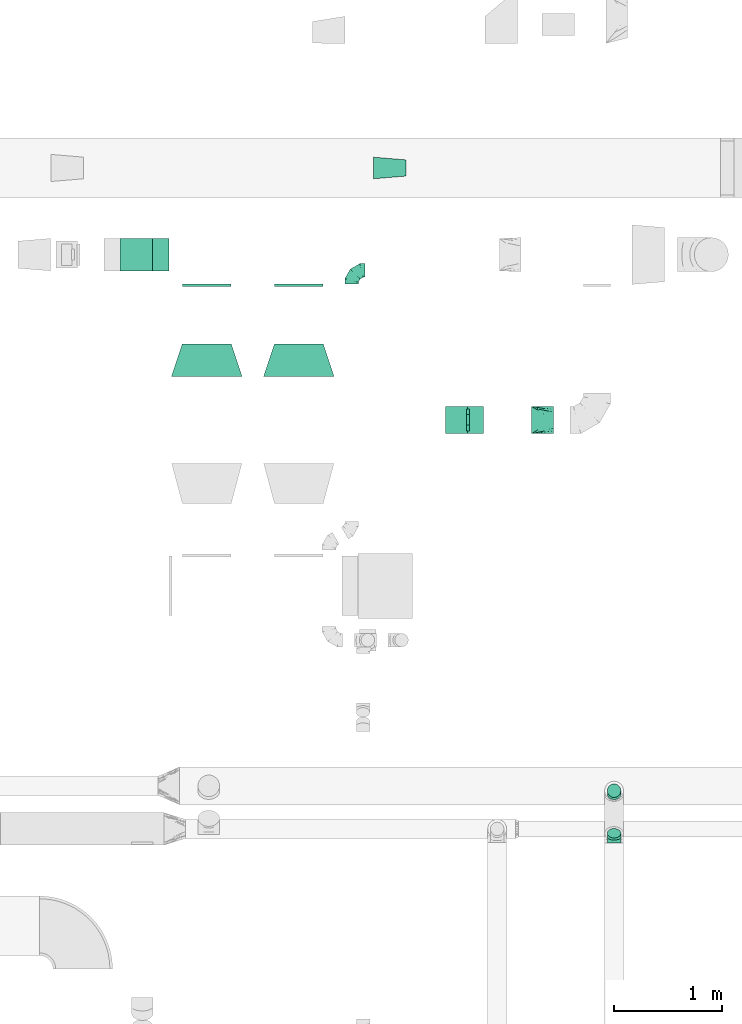
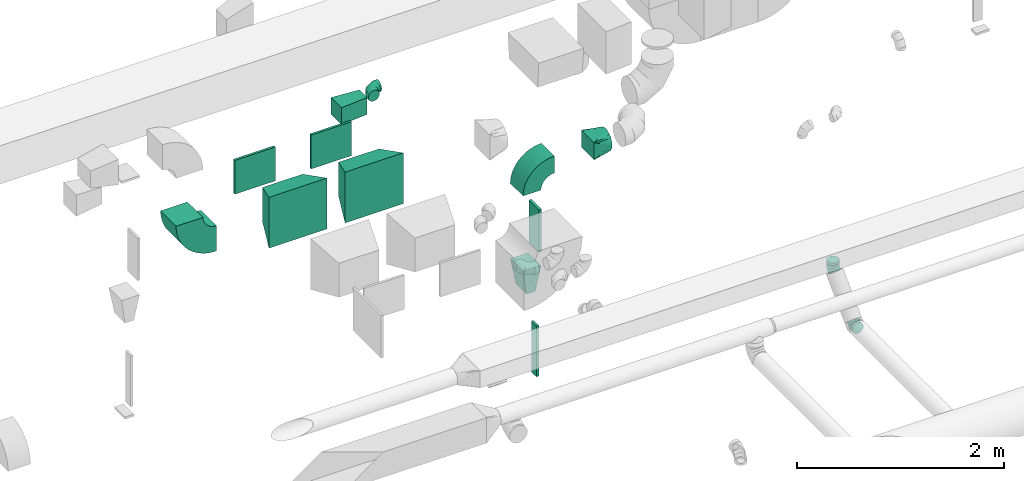
# One storey, part 58 of 97: 15 flow fittings.
"""IFC2X3 building model written with IfcOpenShell, lengths in millimetres."""

from ifc_helpers import new_model, entity, si_unit, converted_unit, derived_unit, direction, frame, frame_2d, origin, origin_2d_with_axis, place, context, subcontext, project, spatial, polyline, circle_curve, parameter, trimmed, segment, composite_curve, rectangle, outline, extrude, faceted_brep, source, transform, mapped, material, type_object, type_shapes, element, save


model = new_model("IFC2X3")

# Units and contexts
model_context = context("Model", 3, precision=0.01, world=origin(), true_north=direction((6.12303176911189e-17, 1.0)))
body_context = subcontext(model_context, "Body", "Model", "MODEL_VIEW")
ifc_project = project(units=[si_unit("LENGTHUNIT", "METRE", prefix="MILLI"), si_unit("AREAUNIT", "SQUARE_METRE"), si_unit("VOLUMEUNIT", "CUBIC_METRE"), converted_unit("PLANEANGLEUNIT", "DEGREE", entity("IfcRatioMeasure", 0.0174532925199433), si_unit("PLANEANGLEUNIT", "RADIAN"), dimensions=[0, 0, 0, 0, 0, 0, 0]), si_unit("MASSUNIT", "GRAM", prefix="KILO"), derived_unit("MASSDENSITYUNIT", [(si_unit("MASSUNIT", "GRAM", prefix="KILO"), 1), (si_unit("LENGTHUNIT", "METRE"), -3)]), derived_unit("MOMENTOFINERTIAUNIT", [(si_unit("LENGTHUNIT", "METRE"), 4)]), si_unit("TIMEUNIT", "SECOND"), si_unit("FREQUENCYUNIT", "HERTZ"), si_unit("THERMODYNAMICTEMPERATUREUNIT", "DEGREE_CELSIUS"), derived_unit("THERMALTRANSMITTANCEUNIT", [(si_unit("MASSUNIT", "GRAM", prefix="KILO"), 1), (si_unit("THERMODYNAMICTEMPERATUREUNIT", "KELVIN"), -1), (si_unit("TIMEUNIT", "SECOND"), -3)]), derived_unit("VOLUMETRICFLOWRATEUNIT", [(si_unit("LENGTHUNIT", "METRE"), 3), (si_unit("TIMEUNIT", "SECOND"), -1)]), derived_unit("MASSFLOWRATEUNIT", [(si_unit("MASSUNIT", "GRAM", prefix="KILO"), 1), (si_unit("TIMEUNIT", "SECOND"), -1)]), derived_unit("ROTATIONALFREQUENCYUNIT", [(si_unit("TIMEUNIT", "SECOND"), -1)]), si_unit("ELECTRICCURRENTUNIT", "AMPERE"), si_unit("ELECTRICVOLTAGEUNIT", "VOLT"), si_unit("POWERUNIT", "WATT"), si_unit("FORCEUNIT", "NEWTON", prefix="KILO"), si_unit("ILLUMINANCEUNIT", "LUX"), si_unit("LUMINOUSFLUXUNIT", "LUMEN"), si_unit("LUMINOUSINTENSITYUNIT", "CANDELA"), derived_unit("USERDEFINED", [(si_unit("MASSUNIT", "GRAM", prefix="KILO"), -1), (si_unit("LENGTHUNIT", "METRE"), -2), (si_unit("TIMEUNIT", "SECOND"), 3), (si_unit("LUMINOUSFLUXUNIT", "LUMEN"), 1)]), derived_unit("LINEARVELOCITYUNIT", [(si_unit("LENGTHUNIT", "METRE"), 1), (si_unit("TIMEUNIT", "SECOND"), -1)]), si_unit("PRESSUREUNIT", "PASCAL"), derived_unit("USERDEFINED", [(si_unit("LENGTHUNIT", "METRE"), -2), (si_unit("MASSUNIT", "GRAM", prefix="KILO"), 1), (si_unit("TIMEUNIT", "SECOND"), -2)]), derived_unit("LINEARFORCEUNIT", [(si_unit("MASSUNIT", "GRAM", prefix="KILO"), 1), (si_unit("LENGTHUNIT", "METRE"), 1), (si_unit("TIMEUNIT", "SECOND"), -2), (si_unit("LENGTHUNIT", "METRE"), -1)]), derived_unit("PLANARFORCEUNIT", [(si_unit("MASSUNIT", "GRAM", prefix="KILO"), 1), (si_unit("LENGTHUNIT", "METRE"), 1), (si_unit("TIMEUNIT", "SECOND"), -2), (si_unit("LENGTHUNIT", "METRE"), -2)])], contexts=[model_context])

# Site, building, storey
site_placement = place(None, origin())
site = spatial("IfcSite", under=ifc_project, at=site_placement, CompositionType="ELEMENT")
building_placement = place(site_placement, origin())
building = spatial("IfcBuilding", under=site, at=building_placement, CompositionType="ELEMENT")
storey_placement = place(building_placement, frame((0.0, 0.0, -4900.0)))
storey = spatial("IfcBuildingStorey", under=building, at=storey_placement, CompositionType="ELEMENT", Elevation=-4900.0)

# Flow fittings
ifc_material = material()
duct_fitting_type_1 = type_object("IfcDuctFittingType", PredefinedType="NOTDEFINED", material=ifc_material)
shared_shape_1 = source(origin(), body_context, "Body", "SweptSolid", [
    extrude(outline(polyline([(-143.25, -87.2), (157.79, -87.2), (141.18, 112.11), (-155.71, 62.28), (-143.25, -87.2)])), frame((150.0, 0.0, -100.0), z_axis=(0.0, 0.0, 1.0), x_axis=(0.996545758244879, -0.0830454798537418, 0.0)), (0.0, 0.0, 1.0), 200.0),
])
type_shapes(duct_fitting_type_1, [shared_shape_1])
flow_fitting_1_placement = place(storey_placement, frame((45445.8, 15348.96, 3300.0), z_axis=(0.0, 0.0, 1.0), x_axis=(-1.0, 0.0, 0.0)))
element("IfcFlowFitting", 1, at=flow_fitting_1_placement, inside=storey, type_object=duct_fitting_type_1, material=ifc_material, context=body_context, shape_type="MappedRepresentation", body=[
    mapped(shared_shape_1, transform((0.0, 0.0, 0.0), scale=1.0)),
])
duct_fitting_type_2 = type_object("IfcDuctFittingType", PredefinedType="NOTDEFINED", material=ifc_material)
shared_shape_2 = source(origin(), body_context, "Body", "SweptSolid", [
    extrude(rectangle(XDim=26.0960000000008, YDim=500.0, at=origin_2d_with_axis()), frame((6.95, 0.0, -100.0)), (0.0, 0.0, 1.0), 200.0),
])
type_shapes(duct_fitting_type_2, [shared_shape_2])
flow_fitting_2_placement = place(storey_placement, frame((46014.19, 13020.83, 3050.0), z_axis=(0.0, -1.0, 0.0), x_axis=(1.0, 0.0, 0.0)))
element("IfcFlowFitting", 2, at=flow_fitting_2_placement, inside=storey, type_object=duct_fitting_type_2, material=ifc_material, context=body_context, shape_type="MappedRepresentation", body=[
    mapped(shared_shape_2, transform((0.0, 0.0, 0.0), scale=1.0)),
])
duct_fitting_type_3 = type_object("IfcDuctFittingType", PredefinedType="NOTDEFINED", material=ifc_material)
shared_shape_3 = source(origin(), body_context, "Body", "SweptSolid", [
    extrude(rectangle(XDim=26.0960000000009, YDim=600.0, at=origin_2d_with_axis()), frame((6.95, 0.0, -50.0)), (0.0, 0.0, 1.0), 100.0),
])
type_shapes(duct_fitting_type_3, [shared_shape_3])
flow_fitting_3_placement = place(storey_placement, frame((46014.19, 13024.36, 1600.0), z_axis=(0.0, -1.0, 0.0), x_axis=(1.0, 0.0, 0.0)))
element("IfcFlowFitting", 3, at=flow_fitting_3_placement, inside=storey, type_object=duct_fitting_type_3, material=ifc_material, context=body_context, shape_type="MappedRepresentation", body=[
    mapped(shared_shape_3, transform((0.0, 0.0, 0.0), scale=1.0)),
])
duct_fitting_type_4 = type_object("IfcDuctFittingType", PredefinedType="NOTDEFINED", material=ifc_material)
shared_shape_4 = source(origin(), body_context, "Body", "SweptSolid", [
    extrude(rectangle(XDim=26.0960000000029, YDim=450.0, at=origin_2d_with_axis()), frame((6.95, 0.0, -200.0)), (0.0, 0.0, 1.0), 400.0),
])
type_shapes(duct_fitting_type_4, [shared_shape_4])
for number, where, z_axis, x_axis in (
    (4, (43607.27, 14273.39, 3800.0), (0.0, 0.0, -1.0), (0.0, -1.0, 0.0)),
    (5, (44457.27, 14273.39, 3800.0), (0.0, 0.0, -1.0), (0.0, -1.0, 0.0)),
):
    element("IfcFlowFitting", number, at=place(storey_placement, frame(where, z_axis=z_axis, x_axis=x_axis)), inside=storey, type_object=duct_fitting_type_4, material=ifc_material, context=body_context, shape_type="MappedRepresentation", body=[
        mapped(shared_shape_4, transform((0.0, 0.0, 0.0), scale=1.0)),
    ])
duct_fitting_type_5 = type_object("IfcDuctFittingType", PredefinedType="NOTDEFINED", material=ifc_material)
shared_shape_5 = source(origin(), body_context, "Body", "Brep", [
    faceted_brep([(-125.0, 0.0, -62.5), (-125.0, -16.18, -60.37), (-125.0, -31.25, -54.13), (-125.0, -44.19, -44.19), (-125.0, -54.13, -31.25), (-125.0, -60.37, -16.18), (-125.0, -62.5, 0.0), (-125.0, -60.37, 16.18), (-125.0, -54.13, 31.25), (-125.0, -44.19, 44.19), (-125.0, -31.25, 54.13), (-125.0, -16.18, 60.37), (-125.0, 0.0, 62.5), (-125.0, 16.18, 60.37), (-125.0, 31.25, 54.13), (-125.0, 44.19, 44.19), (-125.0, 54.13, 31.25), (-125.0, 60.37, 16.18), (-125.0, 62.5, 0.0), (-125.0, 60.37, -16.18), (-125.0, 54.13, -31.25), (-125.0, 44.19, -44.19), (-125.0, 31.25, -54.13), (-125.0, 16.18, -60.37), (-95.84, 16.18, 60.37), (-99.88, 31.25, 54.13), (-91.51, 0.0, 62.5), (-103.35, 44.19, 44.19), (-107.68, 60.37, 16.18), (-108.25, 62.5, 0.0), (-106.01, 54.13, 31.25), (-106.01, 54.13, -31.25), (-103.35, 44.19, -44.19), (-107.68, 60.37, -16.18), (-95.84, 16.18, -60.37), (-91.51, 0.0, -62.5), (-99.88, 31.25, -54.13), (-87.17, -16.18, -60.37), (-83.13, -31.25, -54.13), (-79.66, -44.19, -44.19), (-77.0, -54.13, -31.25), (-75.33, -60.37, -16.18), (-74.76, -62.5, 0.0), (-75.33, -60.37, 16.18), (-77.0, -54.13, 31.25), (-79.66, -44.19, 44.19), (-83.13, -31.25, 54.13), (-87.17, -16.18, 60.37), (-45.34, 45.34, 60.37), (-56.37, 56.37, 54.13), (-33.49, 33.49, 62.5), (-65.85, 65.85, 44.19), (-73.12, 73.12, 31.25), (-77.69, 77.69, 16.18), (-79.25, 79.25, 0.0), (-77.69, 77.69, -16.18), (-73.12, 73.12, -31.25), (-65.85, 65.85, -44.19), (-45.34, 45.34, -60.37), (-33.49, 33.49, -62.5), (-56.37, 56.37, -54.13), (-21.65, 21.65, -60.37), (-10.62, 10.62, -54.13), (-1.14, 1.14, -44.19), (6.13, -6.13, -31.25), (10.7, -10.7, -16.18), (12.26, -12.26, 0.0), (10.7, -10.7, 16.18), (6.13, -6.13, 31.25), (-1.14, 1.14, 44.19), (-10.62, 10.62, 54.13), (-21.65, 21.65, 60.37), (-16.18, 95.84, 60.37), (-31.25, 99.88, 54.13), (0.0, 91.51, 62.5), (-44.19, 103.35, 44.19), (-54.13, 106.01, 31.25), (-60.37, 107.68, 16.18), (-62.5, 108.25, 0.0), (-60.37, 107.68, -16.18), (-54.13, 106.01, -31.25), (-44.19, 103.35, -44.19), (-16.18, 95.84, -60.37), (0.0, 91.51, -62.5), (-31.25, 99.88, -54.13), (16.18, 87.17, -60.37), (31.25, 83.13, -54.13), (44.19, 79.66, -44.19), (54.13, 77.0, -31.25), (60.37, 75.33, -16.18), (62.5, 74.76, 0.0), (60.37, 75.33, 16.18), (54.13, 77.0, 31.25), (44.19, 79.66, 44.19), (31.25, 83.13, 54.13), (16.18, 87.17, 60.37), (-16.18, 125.0, -60.37), (-31.25, 125.0, -54.13), (-44.19, 125.0, -44.19), (-54.13, 125.0, -31.25), (-60.37, 125.0, -16.18), (-62.5, 125.0, 0.0), (-60.37, 125.0, 16.18), (-54.13, 125.0, 31.25), (-44.19, 125.0, 44.19), (-31.25, 125.0, 54.13), (-16.18, 125.0, 60.37), (0.0, 125.0, 62.5), (16.18, 125.0, 60.37), (31.25, 125.0, 54.13), (44.19, 125.0, 44.19), (54.13, 125.0, 31.25), (60.37, 125.0, 16.18), (62.5, 125.0, 0.0), (60.37, 125.0, -16.18), (54.13, 125.0, -31.25), (44.19, 125.0, -44.19), (31.25, 125.0, -54.13), (16.18, 125.0, -60.37), (0.0, 125.0, -62.5)], [[[0, 1, 2, 3, 4, 5, 6, 7, 8, 9, 10, 11, 12, 13, 14, 15, 16, 17, 18, 19, 20, 21, 22, 23]], [[24, 25, 14, 13]], [[26, 24, 13, 12]], [[14, 25, 27, 15]], [[28, 29, 18, 17]], [[30, 28, 17, 16]], [[15, 27, 30, 16]], [[20, 31, 32, 21]], [[33, 31, 20, 19]], [[18, 29, 33, 19]], [[34, 35, 0, 23]], [[36, 34, 23, 22]], [[21, 32, 36, 22]], [[1, 0, 35, 37]], [[2, 1, 37, 38]], [[38, 39, 3, 2]], [[5, 4, 40, 41]], [[6, 5, 41, 42]], [[39, 40, 4, 3]], [[6, 42, 43, 7]], [[7, 43, 44, 8]], [[45, 9, 8, 44]], [[9, 45, 46, 10]], [[10, 46, 47, 11]], [[26, 12, 11, 47]], [[48, 49, 25, 24]], [[50, 48, 24, 26]], [[27, 25, 49, 51]], [[52, 53, 28, 30]], [[51, 52, 30, 27]], [[29, 28, 53, 54]], [[55, 56, 31, 33]], [[54, 55, 33, 29]], [[57, 32, 31, 56]], [[58, 59, 35, 34]], [[60, 58, 34, 36]], [[57, 60, 36, 32]], [[37, 35, 59, 61]], [[38, 37, 61, 62]], [[39, 38, 62, 63]], [[41, 40, 64, 65]], [[42, 41, 65, 66]], [[63, 64, 40, 39]], [[43, 42, 66, 67]], [[44, 43, 67, 68]], [[68, 69, 45, 44]], [[46, 45, 69, 70]], [[47, 46, 70, 71]], [[26, 47, 71, 50]], [[72, 73, 49, 48]], [[74, 72, 48, 50]], [[51, 49, 73, 75]], [[76, 77, 53, 52]], [[75, 76, 52, 51]], [[54, 53, 77, 78]], [[79, 80, 56, 55]], [[78, 79, 55, 54]], [[81, 57, 56, 80]], [[82, 83, 59, 58]], [[84, 82, 58, 60]], [[81, 84, 60, 57]], [[61, 59, 83, 85]], [[62, 61, 85, 86]], [[63, 62, 86, 87]], [[65, 64, 88, 89]], [[66, 65, 89, 90]], [[87, 88, 64, 63]], [[67, 66, 90, 91]], [[68, 67, 91, 92]], [[92, 93, 69, 68]], [[70, 69, 93, 94]], [[71, 70, 94, 95]], [[50, 71, 95, 74]], [[96, 97, 98, 99, 100, 101, 102, 103, 104, 105, 106, 107, 108, 109, 110, 111, 112, 113, 114, 115, 116, 117, 118, 119]], [[72, 74, 107, 106]], [[73, 72, 106, 105]], [[75, 73, 105, 104]], [[77, 76, 103, 102]], [[78, 77, 102, 101]], [[75, 104, 103, 76]], [[78, 101, 100, 79]], [[79, 100, 99, 80]], [[80, 99, 98, 81]], [[96, 119, 83, 82]], [[97, 96, 82, 84]], [[84, 81, 98, 97]], [[83, 119, 118, 85]], [[85, 118, 117, 86]], [[116, 87, 86, 117]], [[88, 115, 114, 89]], [[89, 114, 113, 90]], [[115, 88, 87, 116]], [[91, 90, 113, 112]], [[92, 91, 112, 111]], [[111, 110, 93, 92]], [[95, 94, 109, 108]], [[74, 95, 108, 107]], [[110, 109, 94, 93]]]),
])
type_shapes(duct_fitting_type_5, [shared_shape_5])
flow_fitting_4_placement = place(storey_placement, frame((44945.15, 14402.31, 4200.0), z_axis=(0.0, 0.0, 1.0), x_axis=(-1.0, 0.0, 0.0)))
element("IfcFlowFitting", 6, at=flow_fitting_4_placement, inside=storey, type_object=duct_fitting_type_5, material=ifc_material, context=body_context, shape_type="MappedRepresentation", body=[
    mapped(shared_shape_5, transform((0.0, 0.0, 0.0), scale=1.0)),
])
duct_fitting_type_6 = type_object("IfcDuctFittingType", PredefinedType="NOTDEFINED", material=ifc_material)
shared_shape_6 = source(origin(), body_context, "Body", "Brep", [
    faceted_brep([(20.0, 0.0, -62.5), (20.0, 16.18, -60.37), (20.0, 31.25, -54.13), (20.0, 44.19, -44.19), (20.0, 54.13, -31.25), (20.0, 60.37, -16.18), (20.0, 62.5, 0.0), (20.0, 60.37, 16.18), (20.0, 54.13, 31.25), (20.0, 44.19, 44.19), (20.0, 31.25, 54.13), (20.0, 16.18, 60.37), (20.0, 0.0, 62.5), (20.0, -16.18, 60.37), (20.0, -31.25, 54.13), (20.0, -44.19, 44.19), (20.0, -54.13, 31.25), (20.0, -60.37, 16.18), (20.0, -62.5, 0.0), (20.0, -60.37, -16.18), (20.0, -54.13, -31.25), (20.0, -44.19, -44.19), (20.0, -31.25, -54.13), (20.0, -16.18, -60.37), (0.0, 0.0, 62.5), (-6.1, 0.0, 62.5), (-6.1, -16.18, 60.37), (0.0, -16.18, 60.37), (-6.1, -31.25, 54.13), (0.0, -31.25, 54.13), (0.0, -44.19, 44.19), (-6.1, -44.19, 44.19), (0.0, -54.13, 31.25), (-6.1, -54.13, 31.25), (-6.1, -60.37, 16.18), (0.0, -60.37, 16.18), (-6.1, -62.5, 0.0), (0.0, -62.5, 0.0), (-6.1, -60.37, -16.18), (0.0, -60.37, -16.18), (-6.1, -54.13, -31.25), (0.0, -54.13, -31.25), (0.0, -44.19, -44.19), (-6.1, -44.19, -44.19), (0.0, -31.25, -54.13), (-6.1, -31.25, -54.13), (-6.1, -16.18, -60.37), (0.0, -16.18, -60.37), (-6.1, 0.0, -62.5), (0.0, 0.0, -62.5), (-6.1, 16.18, -60.37), (0.0, 16.18, -60.37), (-6.1, 31.25, -54.13), (0.0, 31.25, -54.13), (0.0, 44.19, -44.19), (-6.1, 44.19, -44.19), (0.0, 54.13, -31.25), (-6.1, 54.13, -31.25), (-6.1, 60.37, -16.18), (0.0, 60.37, -16.18), (-6.1, 62.5, 0.0), (0.0, 62.5, 0.0), (-6.1, 60.37, 16.18), (0.0, 60.37, 16.18), (-6.1, 54.13, 31.25), (0.0, 54.13, 31.25), (0.0, 44.19, 44.19), (-6.1, 44.19, 44.19), (0.0, 31.25, 54.13), (-6.1, 31.25, 54.13), (-6.1, 16.18, 60.37), (0.0, 16.18, 60.37)], [[[0, 1, 2, 3, 4, 5, 6, 7, 8, 9, 10, 11, 12, 13, 14, 15, 16, 17, 18, 19, 20, 21, 22, 23]], [[13, 12, 24, 25, 26, 27]], [[14, 13, 27, 26, 28, 29]], [[30, 15, 14, 29, 28, 31]], [[17, 16, 32, 33, 34, 35]], [[18, 17, 35, 34, 36, 37]], [[32, 16, 15, 30, 31, 33]], [[19, 18, 37, 36, 38, 39]], [[20, 19, 39, 38, 40, 41]], [[42, 21, 20, 41, 40, 43]], [[23, 22, 44, 45, 46, 47]], [[0, 23, 47, 46, 48, 49]], [[44, 22, 21, 42, 43, 45]], [[1, 0, 49, 48, 50, 51]], [[2, 1, 51, 50, 52, 53]], [[54, 3, 2, 53, 52, 55]], [[5, 4, 56, 57, 58, 59]], [[6, 5, 59, 58, 60, 61]], [[56, 4, 3, 54, 55, 57]], [[7, 6, 61, 60, 62, 63]], [[8, 7, 63, 62, 64, 65]], [[66, 9, 8, 65, 64, 67]], [[11, 10, 68, 69, 70, 71]], [[12, 11, 71, 70, 25, 24]], [[68, 10, 9, 66, 67, 69]], [[46, 45, 43, 40, 38, 36, 34, 33, 31, 28, 26, 25, 70, 69, 67, 64, 62, 60, 58, 57, 55, 52, 50, 48]]]),
])
type_shapes(duct_fitting_type_6, [shared_shape_6])
flow_fitting_5_placement = place(storey_placement, frame((47368.94, 9598.15, 4250.0), z_axis=(1.0, 0.0, 0.0), x_axis=(0.0, 0.0, -1.0)))
element("IfcFlowFitting", 7, at=flow_fitting_5_placement, inside=storey, type_object=duct_fitting_type_6, material=ifc_material, context=body_context, shape_type="MappedRepresentation", body=[
    mapped(shared_shape_6, transform((0.0, 0.0, 0.0), scale=1.0)),
])
duct_fitting_type_7 = type_object("IfcDuctFittingType", PredefinedType="NOTDEFINED", material=ifc_material)
shared_shape_7 = source(origin(), body_context, "Body", "Brep", [
    faceted_brep([(-51.78, 0.0, -62.5), (-51.78, -16.18, -60.37), (-51.78, -31.25, -54.13), (-51.78, -44.19, -44.19), (-51.78, -54.13, -31.25), (-51.78, -60.37, -16.18), (-51.78, -62.5, 0.0), (-51.78, -60.37, 16.18), (-51.78, -54.13, 31.25), (-51.78, -44.19, 44.19), (-51.78, -31.25, 54.13), (-51.78, -16.18, 60.37), (-51.78, 0.0, 62.5), (-51.78, 16.18, 60.37), (-51.78, 31.25, 54.13), (-51.78, 44.19, 44.19), (-51.78, 54.13, 31.25), (-51.78, 60.37, 16.18), (-51.78, 62.5, 0.0), (-51.78, 60.37, -16.18), (-51.78, 54.13, -31.25), (-51.78, 44.19, -44.19), (-51.78, 31.25, -54.13), (-51.78, 16.18, -60.37), (-6.7, 16.18, 60.37), (-12.94, 31.25, 54.13), (0.0, 0.0, 62.5), (-18.31, 44.19, 44.19), (-22.42, 54.13, 31.25), (-25.01, 60.37, 16.18), (-25.89, 62.5, 0.0), (-25.01, 60.37, -16.18), (-22.42, 54.13, -31.25), (-18.31, 44.19, -44.19), (-6.7, 16.18, -60.37), (0.0, 0.0, -62.5), (-12.94, 31.25, -54.13), (6.7, -16.18, -60.37), (12.94, -31.25, -54.13), (18.31, -44.19, -44.19), (22.42, -54.13, -31.25), (25.01, -60.37, -16.18), (25.89, -62.5, 0.0), (25.01, -60.37, 16.18), (22.42, -54.13, 31.25), (18.31, -44.19, 44.19), (12.94, -31.25, 54.13), (6.7, -16.18, 60.37), (25.17, 48.05, 60.37), (14.51, 58.71, 54.13), (36.61, 36.61, 62.5), (5.36, 67.86, 44.19), (-1.66, 74.88, 31.25), (-6.08, 79.3, 16.18), (-7.58, 80.81, 0.0), (-6.08, 79.3, -16.18), (-1.66, 74.88, -31.25), (5.36, 67.86, -44.19), (14.51, 58.71, -54.13), (25.17, 48.05, -60.37), (36.61, 36.61, -62.5), (48.05, 25.17, -60.37), (58.71, 14.51, -54.13), (67.86, 5.36, -44.19), (74.88, -1.66, -31.25), (79.3, -6.08, -16.18), (80.81, -7.58, 0.0), (79.3, -6.08, 16.18), (74.88, -1.66, 31.25), (67.86, 5.36, 44.19), (58.71, 14.51, 54.13), (48.05, 25.17, 60.37)], [[[0, 1, 2, 3, 4, 5, 6, 7, 8, 9, 10, 11, 12, 13, 14, 15, 16, 17, 18, 19, 20, 21, 22, 23]], [[24, 25, 14, 13]], [[26, 24, 13, 12]], [[27, 15, 14, 25]], [[28, 29, 17, 16]], [[28, 16, 15, 27]], [[30, 18, 17, 29]], [[31, 32, 20, 19]], [[30, 31, 19, 18]], [[21, 20, 32, 33]], [[34, 35, 0, 23]], [[36, 34, 23, 22]], [[33, 36, 22, 21]], [[1, 0, 35, 37]], [[2, 1, 37, 38]], [[38, 39, 3, 2]], [[5, 4, 40, 41]], [[6, 5, 41, 42]], [[39, 40, 4, 3]], [[6, 42, 43, 7]], [[7, 43, 44, 8]], [[8, 44, 45, 9]], [[9, 45, 46, 10]], [[10, 46, 47, 11]], [[26, 12, 11, 47]], [[48, 49, 25, 24]], [[50, 48, 24, 26]], [[27, 25, 49, 51]], [[29, 28, 52, 53]], [[30, 29, 53, 54]], [[51, 52, 28, 27]], [[30, 54, 55, 31]], [[31, 55, 56, 32]], [[57, 33, 32, 56]], [[36, 58, 59, 34]], [[34, 59, 60, 35]], [[58, 36, 33, 57]], [[35, 60, 61, 37]], [[37, 61, 62, 38]], [[63, 39, 38, 62]], [[40, 64, 65, 41]], [[41, 65, 66, 42]], [[64, 40, 39, 63]], [[43, 42, 66, 67]], [[44, 43, 67, 68]], [[68, 69, 45, 44]], [[47, 46, 70, 71]], [[26, 47, 71, 50]], [[69, 70, 46, 45]], [[59, 58, 57, 56, 55, 54, 53, 52, 51, 49, 48, 50, 71, 70, 69, 68, 67, 66, 65, 64, 63, 62, 61, 60]]]),
])
type_shapes(duct_fitting_type_7, [shared_shape_7])
for number, where, z_axis, x_axis in (
    (8, (47368.94, 9598.15, 4170.0), (-1.0, 0.0, 0.0), (0.0, 0.0, -1.0)),
    (9, (47368.94, 9168.15, 3740.0), (1.0, 0.0, 0.0), (0.0, 1.0, 0.0)),
):
    element("IfcFlowFitting", number, at=place(storey_placement, frame(where, z_axis=z_axis, x_axis=x_axis)), inside=storey, type_object=duct_fitting_type_7, material=ifc_material, context=body_context, shape_type="MappedRepresentation", body=[
        mapped(shared_shape_7, transform((0.0, 0.0, 0.0), scale=1.0)),
    ])
duct_fitting_type_8 = type_object("IfcDuctFittingType", PredefinedType="NOTDEFINED", material=ifc_material)
shared_shape_8 = source(origin(), body_context, "Body", "Brep", [
    faceted_brep([(300.0, -225.0, 200.0), (300.0, -225.0, -200.0), (300.0, 225.0, -200.0), (300.0, 225.0, 200.0), (0.0, -325.0, 300.0), (0.0, 325.0, 300.0), (0.0, 325.0, -300.0), (0.0, -325.0, -300.0)], [[[0, 1, 2, 3]], [[4, 5, 6, 7]], [[4, 7, 1, 0]], [[7, 6, 2, 1]], [[6, 5, 3, 2]], [[5, 4, 0, 3]]]),
])
type_shapes(duct_fitting_type_8, [shared_shape_8])
for number, where, z_axis, x_axis in (
    (10, (43607.27, 13425.33, 3800.0), (0.0, 0.0, 1.0), (0.0, 1.0, 0.0)),
    (11, (44457.27, 13425.33, 3800.0), (0.0, 0.0, 1.0), (0.0, 1.0, 0.0)),
):
    element("IfcFlowFitting", number, at=place(storey_placement, frame(where, z_axis=z_axis, x_axis=x_axis)), inside=storey, type_object=duct_fitting_type_8, material=ifc_material, context=body_context, shape_type="MappedRepresentation", body=[
        mapped(shared_shape_8, transform((0.0, 0.0, 0.0), scale=1.0)),
    ])
duct_fitting_type_9 = type_object("IfcDuctFittingType", PredefinedType="NOTDEFINED", material=ifc_material)
shared_shape_9 = source(origin(), body_context, "Body", "Brep", [
    faceted_brep([(200.0, 73.47, 101.13), (200.0, 56.05, 110.0), (200.0, 38.63, 118.88), (200.0, 23.84, 121.22), (200.0, 11.92, 123.11), (200.0, 5.96, 124.06), (200.0, 0.0, 125.0), (200.0, -5.96, 124.06), (200.0, -11.92, 123.11), (200.0, -23.84, 121.22), (200.0, -38.63, 118.88), (200.0, -56.05, 110.0), (200.0, -73.47, 101.13), (200.0, -87.3, 87.3), (200.0, -101.13, 73.47), (200.0, -110.0, 56.05), (200.0, -118.88, 38.63), (200.0, -121.22, 23.84), (200.0, -123.11, 11.92), (200.0, -124.06, 5.96), (200.0, -125.0, 0.0), (200.0, -124.06, -5.96), (200.0, -123.11, -11.92), (200.0, -121.22, -23.84), (200.0, -118.88, -38.63), (200.0, -110.0, -56.05), (200.0, -101.13, -73.47), (200.0, -87.3, -87.3), (200.0, -73.47, -101.13), (200.0, -56.05, -110.0), (200.0, -38.63, -118.88), (200.0, -23.84, -121.22), (200.0, -11.92, -123.11), (200.0, -5.96, -124.06), (200.0, 0.0, -125.0), (200.0, 5.96, -124.06), (200.0, 11.92, -123.11), (200.0, 23.84, -121.22), (200.0, 38.63, -118.88), (200.0, 56.05, -110.0), (200.0, 73.47, -101.13), (200.0, 87.3, -87.3), (200.0, 101.13, -73.47), (200.0, 110.0, -56.05), (200.0, 118.88, -38.63), (200.0, 121.22, -23.84), (200.0, 123.11, -11.92), (200.0, 124.06, -5.96), (200.0, 125.0, 0.0), (200.0, 124.06, 5.96), (200.0, 123.11, 11.92), (200.0, 121.22, 23.84), (200.0, 118.88, 38.63), (200.0, 110.0, 56.05), (200.0, 101.13, 73.47), (200.0, 87.3, 87.3), (0.0, -125.0, 100.0), (0.0, 125.0, 100.0), (0.0, 125.0, -100.0), (0.0, -125.0, -100.0), (104.11, -59.93, 113.01), (100.0, -103.94, 96.79), (26.03, -108.73, 103.25), (78.09, -76.2, 109.76), (52.06, -92.46, 106.51), (188.01, -7.49, 123.5), (176.03, -14.98, 122.0), (152.06, -29.96, 119.01), (128.09, -44.95, 116.01), (52.06, -125.0, 73.97), (78.09, -125.0, 60.96), (104.11, -125.0, 47.94), (128.09, -125.0, 35.96), (152.06, -125.0, 23.97), (176.03, -125.0, 11.99), (188.01, -125.0, 5.99), (26.03, -125.0, 86.99), (26.03, -125.0, -86.99), (52.06, -125.0, -73.97), (78.09, -125.0, -60.96), (104.11, -125.0, -47.94), (128.09, -125.0, -35.96), (152.06, -125.0, -23.97), (176.03, -125.0, -11.99), (188.01, -125.0, -5.99), (100.0, -109.29, -91.44), (52.06, -92.46, -106.51), (78.09, -76.2, -109.76), (104.11, -59.93, -113.01), (128.09, -44.95, -116.01), (152.06, -29.96, -119.01), (176.03, -14.98, -122.0), (188.01, -7.49, -123.5), (26.03, -108.73, -103.25), (26.03, 108.73, -103.25), (52.06, 92.46, -106.51), (78.09, 76.2, -109.76), (104.11, 59.93, -113.01), (128.09, 44.95, -116.01), (152.06, 29.96, -119.01), (176.03, 14.98, -122.0), (188.01, 7.49, -123.5), (100.0, 103.94, -96.79), (52.06, 125.0, -73.97), (78.09, 125.0, -60.96), (104.11, 125.0, -47.94), (128.09, 125.0, -35.96), (152.06, 125.0, -23.97), (176.03, 125.0, -11.99), (188.01, 125.0, -5.99), (26.03, 125.0, -86.99), (26.03, 125.0, 86.99), (52.06, 125.0, 73.97), (78.09, 125.0, 60.96), (104.11, 125.0, 47.94), (128.09, 125.0, 35.96), (152.06, 125.0, 23.97), (176.03, 125.0, 11.99), (188.01, 125.0, 5.99), (100.0, 109.29, 91.44), (52.06, 92.46, 106.51), (78.09, 76.2, 109.76), (104.11, 59.93, 113.01), (128.09, 44.95, 116.01), (152.06, 29.96, 119.01), (176.03, 14.98, 122.0), (188.01, 7.49, 123.5), (26.03, 108.73, 103.25)], [[[0, 1, 2, 3, 4, 5, 6, 7, 8, 9, 10, 11, 12, 13, 14, 15, 16, 17, 18, 19, 20, 21, 22, 23, 24, 25, 26, 27, 28, 29, 30, 31, 32, 33, 34, 35, 36, 37, 38, 39, 40, 41, 42, 43, 44, 45, 46, 47, 48, 49, 50, 51, 52, 53, 54, 55]], [[56, 57, 58, 59]], [[60, 11, 10]], [[56, 61, 62]], [[11, 60, 63, 64]], [[65, 66, 67, 68, 60, 10, 9, 8, 7, 6]], [[62, 61, 12]], [[15, 69, 70, 71]], [[64, 12, 11]], [[16, 71, 72, 73, 74, 75, 20, 19, 18, 17]], [[14, 76, 69]], [[71, 16, 15]], [[61, 76, 13]], [[12, 64, 62]], [[76, 14, 13]], [[12, 61, 13]], [[61, 56, 76]], [[69, 15, 14]], [[75, 74, 73, 72, 71, 70, 69, 76, 56, 59, 77, 78, 79, 80, 81, 82, 83, 84, 20]], [[80, 25, 24]], [[59, 85, 77]], [[25, 80, 79, 78]], [[84, 83, 82, 81, 80, 24, 23, 22, 21, 20]], [[77, 85, 26]], [[29, 86, 87, 88]], [[78, 26, 25]], [[30, 88, 89, 90, 91, 92, 34, 33, 32, 31]], [[28, 93, 86]], [[88, 30, 29]], [[85, 93, 27]], [[26, 78, 77]], [[93, 28, 27]], [[26, 85, 27]], [[85, 59, 93]], [[86, 29, 28]], [[92, 91, 90, 89, 88, 87, 86, 93, 59, 58, 94, 95, 96, 97, 98, 99, 100, 101, 34]], [[97, 39, 38]], [[58, 102, 94]], [[39, 97, 96, 95]], [[101, 100, 99, 98, 97, 38, 37, 36, 35, 34]], [[94, 102, 40]], [[43, 103, 104, 105]], [[95, 40, 39]], [[44, 105, 106, 107, 108, 109, 48, 47, 46, 45]], [[42, 110, 103]], [[105, 44, 43]], [[102, 110, 41]], [[40, 95, 94]], [[110, 42, 41]], [[40, 102, 41]], [[102, 58, 110]], [[103, 43, 42]], [[58, 57, 111, 112, 113, 114, 115, 116, 117, 118, 48, 109, 108, 107, 106, 105, 104, 103, 110]], [[114, 53, 52]], [[57, 119, 111]], [[53, 114, 113, 112]], [[118, 117, 116, 115, 114, 52, 51, 50, 49, 48]], [[111, 119, 54]], [[1, 120, 121, 122]], [[112, 54, 53]], [[2, 122, 123, 124, 125, 126, 6, 5, 4, 3]], [[0, 127, 120]], [[122, 2, 1]], [[119, 127, 55]], [[54, 112, 111]], [[127, 0, 55]], [[54, 119, 55]], [[119, 57, 127]], [[120, 1, 0]], [[57, 56, 62, 64, 63, 60, 68, 67, 66, 65, 6, 126, 125, 124, 123, 122, 121, 120, 127]]]),
])
type_shapes(duct_fitting_type_9, [shared_shape_9])
flow_fitting_6_placement = place(storey_placement, frame((46608.09, 13020.83, 3800.0)))
element("IfcFlowFitting", 12, at=flow_fitting_6_placement, inside=storey, type_object=duct_fitting_type_9, material=ifc_material, context=body_context, shape_type="MappedRepresentation", body=[
    mapped(shared_shape_9, transform((0.0, 0.0, 0.0), scale=1.0)),
])
duct_fitting_type_10 = type_object("IfcDuctFittingType", PredefinedType="NOTDEFINED", material=ifc_material)
shared_shape_10 = source(origin(), body_context, "Body", "Brep", [
    faceted_brep([(300.0, -100.0, 125.0), (300.0, -100.0, -125.0), (300.0, 100.0, -125.0), (300.0, 100.0, 125.0), (0.0, -50.0, 100.0), (0.0, 50.0, 100.0), (0.0, 50.0, -100.0), (0.0, -50.0, -100.0)], [[[0, 1, 2, 3]], [[4, 5, 6, 7]], [[4, 7, 1, 0]], [[7, 6, 2, 1]], [[6, 5, 3, 2]], [[5, 4, 0, 3]]]),
])
type_shapes(duct_fitting_type_10, [shared_shape_10])
flow_fitting_7_placement = place(storey_placement, frame((45914.19, 13020.83, 2360.0), z_axis=(0.0, -1.0, 0.0), x_axis=(0.0, 0.0, 1.0)))
element("IfcFlowFitting", 13, at=flow_fitting_7_placement, inside=storey, type_object=duct_fitting_type_10, material=ifc_material, context=body_context, shape_type="MappedRepresentation", body=[
    mapped(shared_shape_10, transform((0.0, 0.0, 0.0), scale=1.0)),
])
duct_fitting_type_11 = type_object("IfcDuctFittingType", PredefinedType="NOTDEFINED", material=ifc_material)
shared_shape_11 = source(origin(), body_context, "Body", "SweptSolid", [
    extrude(outline(composite_curve([segment(polyline([(-300.0, -150.0), (0.0, -150.0)]), True, "CONTINUOUS"), segment(trimmed(circle_curve(frame_2d((150.0, -150.0), x_axis=(0.0, 1.0)), 150.0), [parameter(0.0)], [parameter(90.0)], True, "PARAMETER"), False, "CONTINUOUS"), segment(polyline([(150.0, 0.0), (150.0, 300.0)]), True, "CONTINUOUS"), segment(trimmed(circle_curve(frame_2d((150.0, -150.0), x_axis=(0.0, 1.0)), 450.0), [parameter(0.0)], [parameter(90.0000000000001)], True, "PARAMETER"), True, "CONTINUOUS")], self_intersect=False)), frame((-150.0, 150.0, -150.0), z_axis=(0.0, 0.0, 1.0), x_axis=(-1.0, 0.0, 0.0)), (0.0, 0.0, 1.0), 300.0),
])
type_shapes(duct_fitting_type_11, [shared_shape_11])
flow_fitting_8_placement = place(storey_placement, frame((42957.3, 14548.39, 3035.0), z_axis=(0.0, 1.0, 0.0), x_axis=(-1.0, 0.0, 0.0)))
element("IfcFlowFitting", 14, at=flow_fitting_8_placement, inside=storey, type_object=duct_fitting_type_11, material=ifc_material, context=body_context, shape_type="MappedRepresentation", body=[
    mapped(shared_shape_11, transform((0.0, 0.0, 0.0), scale=1.0)),
])
duct_fitting_type_12 = type_object("IfcDuctFittingType", PredefinedType="NOTDEFINED", material=ifc_material)
shared_shape_12 = source(origin(), body_context, "Body", "SweptSolid", [
    extrude(outline(composite_curve([segment(polyline([(-225.0, -125.0), (-25.0, -125.0)]), True, "CONTINUOUS"), segment(trimmed(circle_curve(frame_2d((125.0, -125.0), x_axis=(0.0, 1.0)), 150.0), [parameter(0.0)], [parameter(90.0)], True, "PARAMETER"), False, "CONTINUOUS"), segment(polyline([(125.0, 25.0), (125.0, 225.0)]), True, "CONTINUOUS"), segment(trimmed(circle_curve(frame_2d((125.0, -125.0), x_axis=(0.0, 1.0)), 350.0), [parameter(0.0)], [parameter(90.0)], True, "PARAMETER"), True, "CONTINUOUS")], self_intersect=False)), frame((-125.0, 125.0, -125.0), z_axis=(0.0, 0.0, 1.0), x_axis=(-1.0, 0.0, 0.0)), (0.0, 0.0, 1.0), 250.0),
])
type_shapes(duct_fitting_type_12, [shared_shape_12])
flow_fitting_9_placement = place(storey_placement, frame((45914.19, 13020.83, 3800.0), z_axis=(0.0, 1.0, 0.0), x_axis=(0.0, 0.0, 1.0)))
element("IfcFlowFitting", 15, at=flow_fitting_9_placement, inside=storey, type_object=duct_fitting_type_12, material=ifc_material, context=body_context, shape_type="MappedRepresentation", body=[
    mapped(shared_shape_12, transform((0.0, 0.0, 0.0), scale=1.0)),
])

save(model, "model.ifc")
